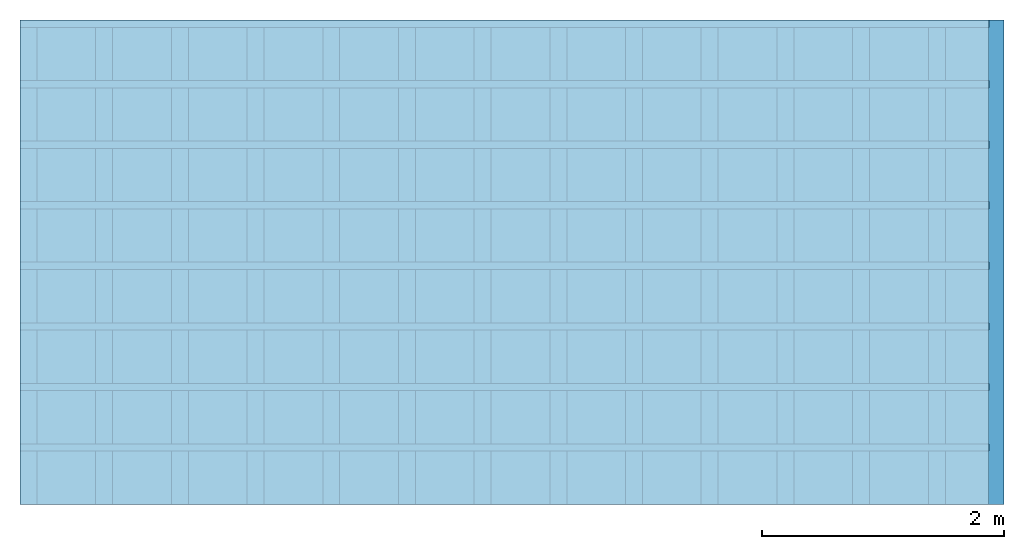
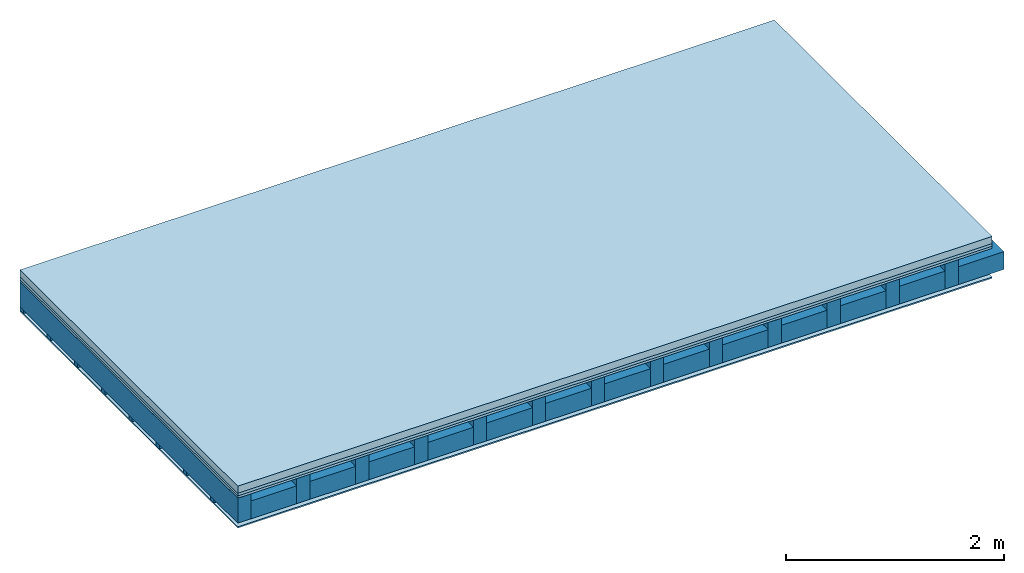
# One storey: 4 plates, 3 members, 1 element without a shape of its own.
"""IFC4 building model written with IfcOpenShell, lengths in metres."""

from ifc_helpers import new_model, si_unit, derived_unit, direction, frame, frame_2d, origin, origin_with_axes, place, context, project, spatial, rectangle, extrude, material, layer, layer_set, type_object, element, aggregate, save


model = new_model("IFC4")

# Units and contexts
plan_context = context("Plan", 3, precision=1e-05, world=origin(), true_north=direction((0.0, 1.0)))
model_context = context("Model", 3, precision=1e-05, world=origin(), true_north=direction((0.0, 1.0)))
ifc_project = project(units=[si_unit("LENGTHUNIT", "METRE"), derived_unit("SOUNDPRESSUREUNIT", [(si_unit("PRESSUREUNIT", "PASCAL", prefix="MICRO"), 0)]), si_unit("ENERGYUNIT", "JOULE", prefix="MEGA"), si_unit("MASSUNIT", "GRAM", prefix="KILO"), derived_unit("THERMALTRANSMITTANCEUNIT", [(si_unit("POWERUNIT", "WATT"), 1), (si_unit("AREAUNIT", "SQUARE_METRE"), -1), (si_unit("THERMODYNAMICTEMPERATUREUNIT", "KELVIN"), -1)]), derived_unit("AREADENSITYUNIT", [(si_unit("MASSUNIT", "GRAM", prefix="KILO"), 1), (si_unit("AREAUNIT", "SQUARE_METRE"), -1)]), derived_unit("USERDEFINED", [(si_unit("ENERGYUNIT", "JOULE", prefix="MEGA"), 1), (si_unit("AREAUNIT", "SQUARE_METRE"), -1)])], contexts=[plan_context, model_context])

# Site, building, storey
site = spatial("IfcSite", under=ifc_project)
building_placement = place(None, origin())
building = spatial("IfcBuilding", under=site, at=building_placement)
storey_placement = place(building_placement, origin())
storey = spatial("IfcBuildingStorey", under=building, at=storey_placement)

# Slab, members, plates
ifc_material_1 = material(Name="Cement screed", Category="04.006")
ifc_layer_1 = layer(ifc_material_1, 0.08, Name="On-material")
ifc_material_2 = material()
ifc_layer_2 = layer(ifc_material_2, 0.03, Name="Impact sound insulation")
ifc_material_3 = material(Category="07.001")
ifc_layer_3 = layer(ifc_material_3, 0.025, Name="Sub-floor")
ifc_material_4 = material(Name="of the art")
ifc_layer_4 = layer(ifc_material_4, 0.0, Name="Bond")
ifc_layer_5 = layer(None, 0.28, Name="Supporting structure")
ifc_layer_6 = layer(ifc_material_4, 0.0, Name="Bond")
ifc_layer_7 = layer(None, 0.04, Name="Battens / profiles")
ifc_material_5 = material(Category="03.007")
ifc_layer_8 = layer(ifc_material_5, 0.015, Name="Ceiling covering 1st layer")
ifc_material_6 = material(Name="Glued joints")
ifc_layer_9 = layer(ifc_material_6, 0.0, Name="Surface / treatment")
ifc_layer_set = layer_set([ifc_layer_1, ifc_layer_2, ifc_layer_3, ifc_layer_4, ifc_layer_5, ifc_layer_6, ifc_layer_7, ifc_layer_8, ifc_layer_9])
slab_type = type_object("IfcSlabType", Name="A0105", PredefinedType="NOTDEFINED", material=ifc_layer_set)
slab_placement = place(None, frame((0.0, 0.0, 0.0), z_axis=(0.0, 0.0, -1.0), x_axis=(1.0, 0.0, 0.0)))
slab = element("IfcSlab", 1, at=slab_placement, inside=storey, type_object=slab_type, material=ifc_layer_set, Name="Slab #1")
ifc_material_7 = material()
member_1_placement = place(slab_placement, origin())
member_1 = element("IfcMember", 2, at=member_1_placement, material=ifc_material_7, Name="Supporting structure", context=plan_context, shape_type="SweptSolid", body=[
    extrude(rectangle(XDim=0.14, YDim=0.28, at=frame_2d((0.07, 0.14), x_axis=(1.0, 0.0))), frame((0.0, 4.0, 0.135), z_axis=(0.0, -1.0, 0.0), x_axis=(1.0, 0.0, 0.0)), (0.0, 0.0, 1.0), 4.0),
    extrude(rectangle(XDim=0.14, YDim=0.28, at=frame_2d((0.07, 0.14), x_axis=(1.0, 0.0))), frame((0.625, 4.0, 0.135), z_axis=(0.0, -1.0, 0.0), x_axis=(1.0, 0.0, 0.0)), (0.0, 0.0, 1.0), 4.0),
    extrude(rectangle(XDim=0.14, YDim=0.28, at=frame_2d((0.07, 0.14), x_axis=(1.0, 0.0))), frame((1.25, 4.0, 0.135), z_axis=(0.0, -1.0, 0.0), x_axis=(1.0, 0.0, 0.0)), (0.0, 0.0, 1.0), 4.0),
    extrude(rectangle(XDim=0.14, YDim=0.28, at=frame_2d((0.07, 0.14), x_axis=(1.0, 0.0))), frame((1.875, 4.0, 0.135), z_axis=(0.0, -1.0, 0.0), x_axis=(1.0, 0.0, 0.0)), (0.0, 0.0, 1.0), 4.0),
    extrude(rectangle(XDim=0.14, YDim=0.28, at=frame_2d((0.07, 0.14), x_axis=(1.0, 0.0))), frame((2.5, 4.0, 0.135), z_axis=(0.0, -1.0, 0.0), x_axis=(1.0, 0.0, 0.0)), (0.0, 0.0, 1.0), 4.0),
    extrude(rectangle(XDim=0.14, YDim=0.28, at=frame_2d((0.07, 0.14), x_axis=(1.0, 0.0))), frame((3.125, 4.0, 0.135), z_axis=(0.0, -1.0, 0.0), x_axis=(1.0, 0.0, 0.0)), (0.0, 0.0, 1.0), 4.0),
    extrude(rectangle(XDim=0.14, YDim=0.28, at=frame_2d((0.07, 0.14), x_axis=(1.0, 0.0))), frame((3.75, 4.0, 0.135), z_axis=(0.0, -1.0, 0.0), x_axis=(1.0, 0.0, 0.0)), (0.0, 0.0, 1.0), 4.0),
    extrude(rectangle(XDim=0.14, YDim=0.28, at=frame_2d((0.07, 0.14), x_axis=(1.0, 0.0))), frame((4.375, 4.0, 0.135), z_axis=(0.0, -1.0, 0.0), x_axis=(1.0, 0.0, 0.0)), (0.0, 0.0, 1.0), 4.0),
    extrude(rectangle(XDim=0.14, YDim=0.28, at=frame_2d((0.07, 0.14), x_axis=(1.0, 0.0))), frame((5.0, 4.0, 0.135), z_axis=(0.0, -1.0, 0.0), x_axis=(1.0, 0.0, 0.0)), (0.0, 0.0, 1.0), 4.0),
    extrude(rectangle(XDim=0.14, YDim=0.28, at=frame_2d((0.07, 0.14), x_axis=(1.0, 0.0))), frame((5.625, 4.0, 0.135), z_axis=(0.0, -1.0, 0.0), x_axis=(1.0, 0.0, 0.0)), (0.0, 0.0, 1.0), 4.0),
    extrude(rectangle(XDim=0.14, YDim=0.28, at=frame_2d((0.07, 0.14), x_axis=(1.0, 0.0))), frame((6.25, 4.0, 0.135), z_axis=(0.0, -1.0, 0.0), x_axis=(1.0, 0.0, 0.0)), (0.0, 0.0, 1.0), 4.0),
    extrude(rectangle(XDim=0.14, YDim=0.28, at=frame_2d((0.07, 0.14), x_axis=(1.0, 0.0))), frame((6.875, 4.0, 0.135), z_axis=(0.0, -1.0, 0.0), x_axis=(1.0, 0.0, 0.0)), (0.0, 0.0, 1.0), 4.0),
    extrude(rectangle(XDim=0.14, YDim=0.28, at=frame_2d((0.07, 0.14), x_axis=(1.0, 0.0))), frame((7.5, 4.0, 0.135), z_axis=(0.0, -1.0, 0.0), x_axis=(1.0, 0.0, 0.0)), (0.0, 0.0, 1.0), 4.0),
])
ifc_material_8 = material()
member_2_placement = place(slab_placement, origin())
member_2 = element("IfcMember", 3, at=member_2_placement, material=ifc_material_8, Name="Cavity", context=plan_context, shape_type="SweptSolid", body=[
    extrude(rectangle(XDim=0.485, YDim=0.2, at=frame_2d((0.2425, 0.1), x_axis=(1.0, 0.0))), frame((0.14, 4.0, 0.215), z_axis=(0.0, -1.0, 0.0), x_axis=(1.0, 0.0, 0.0)), (0.0, 0.0, 1.0), 4.0),
    extrude(rectangle(XDim=0.485, YDim=0.2, at=frame_2d((0.2425, 0.1), x_axis=(1.0, 0.0))), frame((0.765, 4.0, 0.215), z_axis=(0.0, -1.0, 0.0), x_axis=(1.0, 0.0, 0.0)), (0.0, 0.0, 1.0), 4.0),
    extrude(rectangle(XDim=0.485, YDim=0.2, at=frame_2d((0.2425, 0.1), x_axis=(1.0, 0.0))), frame((1.39, 4.0, 0.215), z_axis=(0.0, -1.0, 0.0), x_axis=(1.0, 0.0, 0.0)), (0.0, 0.0, 1.0), 4.0),
    extrude(rectangle(XDim=0.485, YDim=0.2, at=frame_2d((0.2425, 0.1), x_axis=(1.0, 0.0))), frame((2.015, 4.0, 0.215), z_axis=(0.0, -1.0, 0.0), x_axis=(1.0, 0.0, 0.0)), (0.0, 0.0, 1.0), 4.0),
    extrude(rectangle(XDim=0.485, YDim=0.2, at=frame_2d((0.2425, 0.1), x_axis=(1.0, 0.0))), frame((2.64, 4.0, 0.215), z_axis=(0.0, -1.0, 0.0), x_axis=(1.0, 0.0, 0.0)), (0.0, 0.0, 1.0), 4.0),
    extrude(rectangle(XDim=0.485, YDim=0.2, at=frame_2d((0.2425, 0.1), x_axis=(1.0, 0.0))), frame((3.265, 4.0, 0.215), z_axis=(0.0, -1.0, 0.0), x_axis=(1.0, 0.0, 0.0)), (0.0, 0.0, 1.0), 4.0),
    extrude(rectangle(XDim=0.485, YDim=0.2, at=frame_2d((0.2425, 0.1), x_axis=(1.0, 0.0))), frame((3.89, 4.0, 0.215), z_axis=(0.0, -1.0, 0.0), x_axis=(1.0, 0.0, 0.0)), (0.0, 0.0, 1.0), 4.0),
    extrude(rectangle(XDim=0.485, YDim=0.2, at=frame_2d((0.2425, 0.1), x_axis=(1.0, 0.0))), frame((4.515, 4.0, 0.215), z_axis=(0.0, -1.0, 0.0), x_axis=(1.0, 0.0, 0.0)), (0.0, 0.0, 1.0), 4.0),
    extrude(rectangle(XDim=0.485, YDim=0.2, at=frame_2d((0.2425, 0.1), x_axis=(1.0, 0.0))), frame((5.14, 4.0, 0.215), z_axis=(0.0, -1.0, 0.0), x_axis=(1.0, 0.0, 0.0)), (0.0, 0.0, 1.0), 4.0),
    extrude(rectangle(XDim=0.485, YDim=0.2, at=frame_2d((0.2425, 0.1), x_axis=(1.0, 0.0))), frame((5.765, 4.0, 0.215), z_axis=(0.0, -1.0, 0.0), x_axis=(1.0, 0.0, 0.0)), (0.0, 0.0, 1.0), 4.0),
    extrude(rectangle(XDim=0.485, YDim=0.2, at=frame_2d((0.2425, 0.1), x_axis=(1.0, 0.0))), frame((6.39, 4.0, 0.215), z_axis=(0.0, -1.0, 0.0), x_axis=(1.0, 0.0, 0.0)), (0.0, 0.0, 1.0), 4.0),
    extrude(rectangle(XDim=0.485, YDim=0.2, at=frame_2d((0.2425, 0.1), x_axis=(1.0, 0.0))), frame((7.015, 4.0, 0.215), z_axis=(0.0, -1.0, 0.0), x_axis=(1.0, 0.0, 0.0)), (0.0, 0.0, 1.0), 4.0),
    extrude(rectangle(XDim=0.485, YDim=0.2, at=frame_2d((0.2425, 0.1), x_axis=(1.0, 0.0))), frame((7.64, 4.0, 0.215), z_axis=(0.0, -1.0, 0.0), x_axis=(1.0, 0.0, 0.0)), (0.0, 0.0, 1.0), 4.0),
])
ifc_material_9 = material()
member_3_placement = place(slab_placement, origin())
member_3 = element("IfcMember", 4, at=member_3_placement, material=ifc_material_9, Name="Battens / profiles", context=plan_context, shape_type="SweptSolid", body=[
    extrude(rectangle(XDim=0.06, YDim=0.04, at=frame_2d((0.03, 0.02), x_axis=(1.0, 0.0))), frame((0.0, 0.0, 0.415), z_axis=(1.0, 0.0, 0.0), x_axis=(0.0, 1.0, 0.0)), (0.0, 0.0, 1.0), 8.0),
    extrude(rectangle(XDim=0.06, YDim=0.04, at=frame_2d((0.03, 0.02), x_axis=(1.0, 0.0))), frame((0.0, 0.5, 0.415), z_axis=(1.0, 0.0, 0.0), x_axis=(0.0, 1.0, 0.0)), (0.0, 0.0, 1.0), 8.0),
    extrude(rectangle(XDim=0.06, YDim=0.04, at=frame_2d((0.03, 0.02), x_axis=(1.0, 0.0))), frame((0.0, 1.0, 0.415), z_axis=(1.0, 0.0, 0.0), x_axis=(0.0, 1.0, 0.0)), (0.0, 0.0, 1.0), 8.0),
    extrude(rectangle(XDim=0.06, YDim=0.04, at=frame_2d((0.03, 0.02), x_axis=(1.0, 0.0))), frame((0.0, 1.5, 0.415), z_axis=(1.0, 0.0, 0.0), x_axis=(0.0, 1.0, 0.0)), (0.0, 0.0, 1.0), 8.0),
    extrude(rectangle(XDim=0.06, YDim=0.04, at=frame_2d((0.03, 0.02), x_axis=(1.0, 0.0))), frame((0.0, 2.0, 0.415), z_axis=(1.0, 0.0, 0.0), x_axis=(0.0, 1.0, 0.0)), (0.0, 0.0, 1.0), 8.0),
    extrude(rectangle(XDim=0.06, YDim=0.04, at=frame_2d((0.03, 0.02), x_axis=(1.0, 0.0))), frame((0.0, 2.5, 0.415), z_axis=(1.0, 0.0, 0.0), x_axis=(0.0, 1.0, 0.0)), (0.0, 0.0, 1.0), 8.0),
    extrude(rectangle(XDim=0.06, YDim=0.04, at=frame_2d((0.03, 0.02), x_axis=(1.0, 0.0))), frame((0.0, 3.0, 0.415), z_axis=(1.0, 0.0, 0.0), x_axis=(0.0, 1.0, 0.0)), (0.0, 0.0, 1.0), 8.0),
    extrude(rectangle(XDim=0.06, YDim=0.04, at=frame_2d((0.03, 0.02), x_axis=(1.0, 0.0))), frame((0.0, 3.5, 0.415), z_axis=(1.0, 0.0, 0.0), x_axis=(0.0, 1.0, 0.0)), (0.0, 0.0, 1.0), 8.0),
])
plate_1_placement = place(slab_placement, origin())
plate_1 = element("IfcPlate", 5, at=plate_1_placement, material=ifc_material_1, Name="On-material", context=plan_context, shape_type="SweptSolid", body=[
    extrude(rectangle(XDim=8.0, YDim=4.0, at=frame_2d((4.0, 2.0), x_axis=(1.0, 0.0))), origin_with_axes(), (0.0, 0.0, 1.0), 0.08),
])
plate_2_placement = place(slab_placement, origin())
plate_2 = element("IfcPlate", 6, at=plate_2_placement, material=ifc_material_2, Name="Impact sound insulation", context=plan_context, shape_type="SweptSolid", body=[
    extrude(rectangle(XDim=8.0, YDim=4.0, at=frame_2d((4.0, 2.0), x_axis=(1.0, 0.0))), frame((0.0, 0.0, 0.08), z_axis=(0.0, 0.0, 1.0), x_axis=(1.0, 0.0, 0.0)), (0.0, 0.0, 1.0), 0.03),
])
plate_3_placement = place(slab_placement, origin())
plate_3 = element("IfcPlate", 7, at=plate_3_placement, material=ifc_material_3, Name="Sub-floor", context=plan_context, shape_type="SweptSolid", body=[
    extrude(rectangle(XDim=8.0, YDim=4.0, at=frame_2d((4.0, 2.0), x_axis=(1.0, 0.0))), frame((0.0, 0.0, 0.11), z_axis=(0.0, 0.0, 1.0), x_axis=(1.0, 0.0, 0.0)), (0.0, 0.0, 1.0), 0.025),
])
plate_4_placement = place(slab_placement, origin())
plate_4 = element("IfcPlate", 8, at=plate_4_placement, material=ifc_material_5, Name="Ceiling covering 1st layer", context=plan_context, shape_type="SweptSolid", body=[
    extrude(rectangle(XDim=8.0, YDim=4.0, at=frame_2d((4.0, 2.0), x_axis=(1.0, 0.0))), frame((0.0, 0.0, 0.455), z_axis=(0.0, 0.0, 1.0), x_axis=(1.0, 0.0, 0.0)), (0.0, 0.0, 1.0), 0.015),
])
aggregate(slab, [plate_1, plate_2, plate_3, member_1, member_2, member_3, plate_4])

save(model, "model.ifc")
